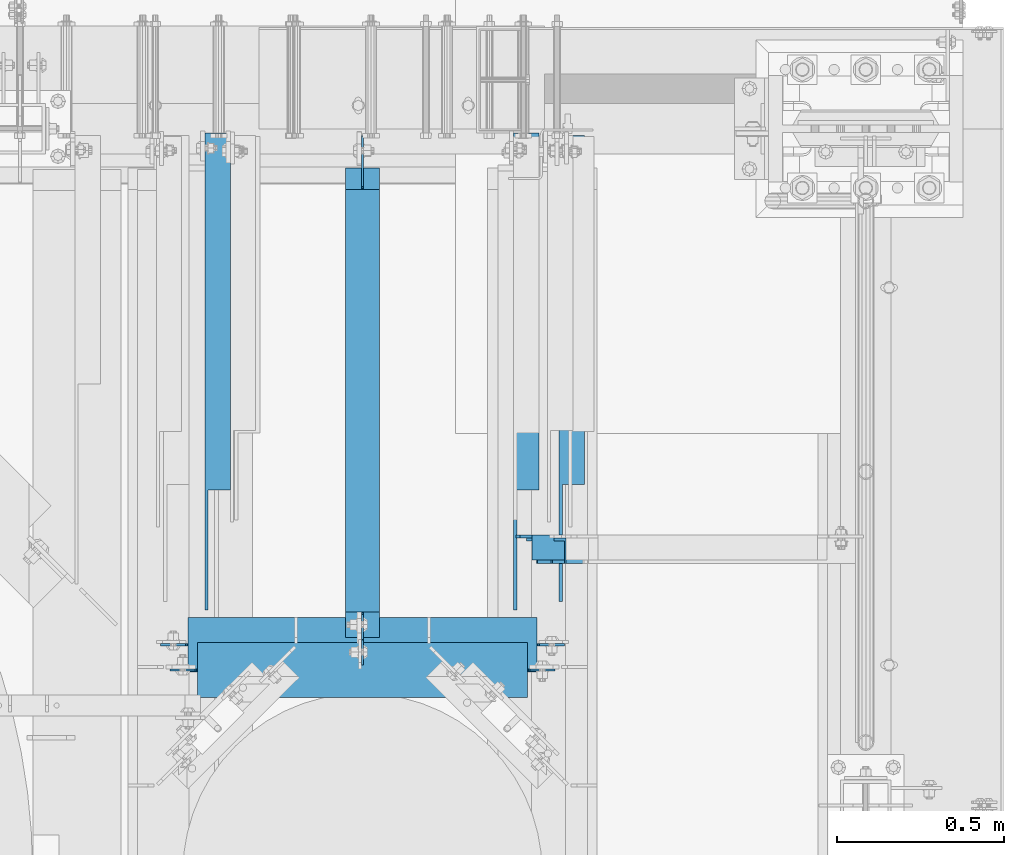
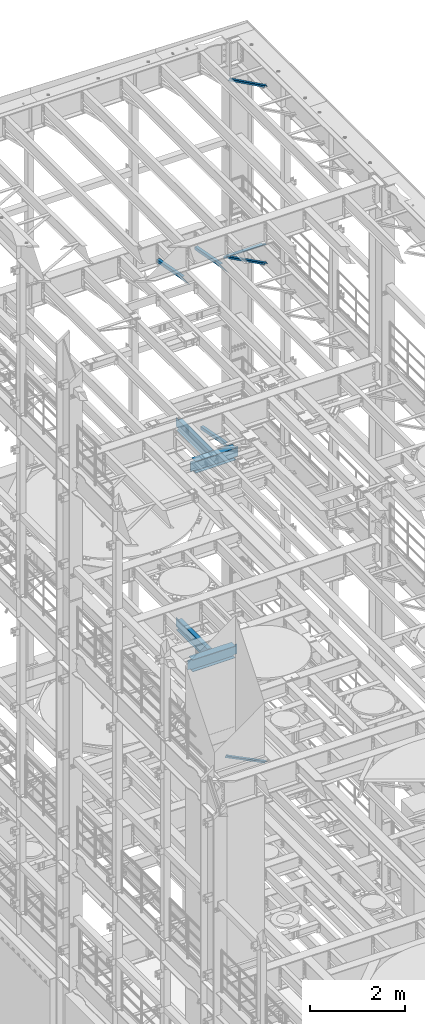
# One storey, part 1069 of 1876: 8 beams, 3 members, 11 elements without a shape of their own.
"""IFC2X3 building model written with IfcOpenShell, lengths in millimetres."""

import ifcopenshell
import ifcopenshell.guid

model = None  # the IFC model being written
_history = None  # IfcOwnerHistory: only IFC2X3 demands one
_inside = {}  # id of a spatial element -> (the spatial element, [elements in it])
_under = {}  # id of a project, library or spatial element -> (it, [spatial elements below it])
_declared = {}  # id of a project -> (the project, [libraries it declares])
_typed = {}  # id of a type object -> (the type object, [elements of that type])
_made_of = {}  # id of a material, layer set ... -> (it, [elements and type objects made of it])


def new_model(schema):
    """Start an empty IFC model of exactly this schema.

    Asked for "IFC4X3", IfcOpenShell would pick the latest addendum, in which some entities
    have other attributes; the version numbers below select the first issue.
    IFC2X3 requires an IfcOwnerHistory on every rooted entity: one is made here for all.
    """
    global model, _history
    if schema == "IFC4X3":
        model = ifcopenshell.file(schema_version=(4, 3, 0, 0))
    else:
        model = ifcopenshell.file(schema=schema)
    _inside.clear()
    _under.clear()
    _declared.clear()
    _typed.clear()
    _made_of.clear()
    _history = None
    if model.schema == "IFC2X3":
        org = make("IfcOrganization", Name="unknown")
        user = make(
            "IfcPersonAndOrganization",
            ThePerson=make("IfcPerson", FamilyName="unknown"),
            TheOrganization=org,
        )
        app = make(
            "IfcApplication",
            ApplicationDeveloper=org,
            Version="unknown",
            ApplicationFullName="unknown",
            ApplicationIdentifier="unknown",
        )
        _history = make(
            "IfcOwnerHistory",
            OwningUser=user,
            OwningApplication=app,
            ChangeAction="ADDED",
            CreationDate=0,
        )
    return model


def make(cls, **values):
    """One entity of the class cls with the attributes given. An attribute that is None is left unset."""
    return model.create_entity(
        cls, **{name: value for name, value in values.items() if value is not None}
    )


def rooted(cls, **values):
    """An entity with a GlobalId (a new one), such as an element, a storey or a relation."""
    return make(cls, GlobalId=ifcopenshell.guid.new(), OwnerHistory=_history, **values)


def si_unit(unit_type, name, prefix=None):
    """IfcSIUnit, for example si_unit("LENGTHUNIT", "METRE", prefix="MILLI")."""
    return make("IfcSIUnit", UnitType=unit_type, Prefix=prefix, Name=name)


def assignment(units):
    """IfcUnitAssignment: the units of a project."""
    return None if units is None else make("IfcUnitAssignment", Units=units)


def point(xyz):
    """IfcCartesianPoint."""
    return None if xyz is None else make("IfcCartesianPoint", Coordinates=xyz)


def direction(xyz):
    """IfcDirection."""
    return None if xyz is None else make("IfcDirection", DirectionRatios=xyz)


def frame(location, z_axis=None, x_axis=None):
    """IfcAxis2Placement3D, a coordinate frame: its origin and axes. An axis left out is left unset."""
    return make(
        "IfcAxis2Placement3D",
        Location=point(location),
        Axis=direction(z_axis),
        RefDirection=direction(x_axis),
    )


def origin_with_axes():
    """The frame at (0, 0, 0) with the z axis (0, 0, 1) and the x axis (1, 0, 0) written out."""
    return frame((0.0, 0.0, 0.0), z_axis=(0.0, 0.0, 1.0), x_axis=(1.0, 0.0, 0.0))


def place(relative_to, where):
    """IfcLocalPlacement: puts the frame where relative to a parent placement (None: the world)."""
    return make(
        "IfcLocalPlacement", PlacementRelTo=relative_to, RelativePlacement=where
    )


def context(
    kind, dimensions, precision=None, world=None, true_north=None, identifier=None
):
    """IfcGeometricRepresentationContext, for example the 3D "Model" context."""
    return make(
        "IfcGeometricRepresentationContext",
        ContextIdentifier=identifier,
        ContextType=kind,
        CoordinateSpaceDimension=dimensions,
        Precision=precision,
        WorldCoordinateSystem=world,
        TrueNorth=true_north,
    )


def subcontext(parent, identifier, kind, view, scale=None):
    """IfcGeometricRepresentationSubContext, for example "Body" below "Model"."""
    return make(
        "IfcGeometricRepresentationSubContext",
        ContextIdentifier=identifier,
        ContextType=kind,
        ParentContext=parent,
        TargetScale=scale,
        TargetView=view,
    )


def project(units=None, contexts=None):
    """IfcProject with its units and contexts."""
    return rooted(
        "IfcProject",
        Name="project",
        RepresentationContexts=contexts,
        UnitsInContext=assignment(units),
    )


def spatial(cls, under=None, at=None, **own):
    """A site, building, storey or space (cls), placed at a placement, below another one or the project."""
    s = rooted(cls, ObjectPlacement=at, **own)
    if under is not None:
        _under.setdefault(under.id(), (under, []))[1].append(s)
    return s


def faces_of(points, faces, orient=None, outer=None):
    """IfcFace entities. A face is a list of loops; a loop is a list of indices into points, from 0.

    orient and outer hold one flag for each loop. By default every Orientation is true, the
    first loop of a face is its IfcFaceOuterBound and the others are IfcFaceBound.
    """
    made = []
    for i, loops in enumerate(faces):
        bounds = []
        for j, loop in enumerate(loops):
            is_outer = j == 0 if outer is None else outer[i][j]
            bounds.append(
                make(
                    "IfcFaceOuterBound" if is_outer else "IfcFaceBound",
                    Bound=make("IfcPolyLoop", Polygon=[points[k] for k in loop]),
                    Orientation=True if orient is None else orient[i][j],
                )
            )
        made.append(make("IfcFace", Bounds=bounds))
    return made


def faceted_brep(points, faces, orient=None, outer=None, voids=None):
    """IfcFacetedBrep: a solid bounded by flat faces; with voids (closed shells), ...WithVoids."""
    shared = [point(p) for p in points]
    hull = make("IfcClosedShell", CfsFaces=faces_of(shared, faces, orient, outer))
    if voids is None:
        return make("IfcFacetedBrep", Outer=hull)
    return make(
        "IfcFacetedBrepWithVoids",
        Outer=hull,
        Voids=[
            make(cls, CfsFaces=faces_of(shared, fs, o, b)) for cls, fs, o, b in voids
        ],
    )


def shape(context_of_items, identifier, shape_type, items):
    """IfcShapeRepresentation: the items that make up one representation, for example the "Body"."""
    return make(
        "IfcShapeRepresentation",
        ContextOfItems=context_of_items,
        RepresentationIdentifier=identifier,
        RepresentationType=shape_type,
        Items=items,
    )


def material(Name=None, Category=None):
    """IfcMaterial."""
    return make("IfcMaterial", Name=Name, Category=Category)


def made_of(thing, what):
    """Note that an element or type object is made of a material, layer set ...; save() writes the relation."""
    if what is not None:
        _made_of.setdefault(what.id(), (what, []))[1].append(thing)
    return thing


def type_object(cls, material=None, **own):
    """A type object (cls), such as IfcWallType, which elements share."""
    return made_of(rooted(cls, **own), material)


def element(
    cls,
    number,
    at=None,
    inside=None,
    cuts=None,
    type_object=None,
    material=None,
    context=None,
    identifier="Body",
    shape_type=None,
    held_by="IfcProductDefinitionShape",
    body=None,
    shapes=None,
    **own,
):
    """One element of the class cls, such as IfcWall. Its Tag is "e" and its number.

    at: its placement. inside: the storey or other place that contains it. cuts: it is an
    opening in that element (IfcRelVoidsElement). A single representation is given by context,
    identifier, shape_type and body (its items); several are given by shapes. held_by: the class
    of the entity that holds the representations. save() writes the other relations.
    """
    e = rooted(cls, Tag="e%d" % number, ObjectPlacement=at, **own)
    if body is not None:
        shapes = [shape(context, identifier, shape_type, body)]
    if shapes is not None:
        e.Representation = make(held_by, Representations=shapes)
    if inside is not None:
        _inside.setdefault(inside.id(), (inside, []))[1].append(e)
    if cuts is not None:
        rooted(
            "IfcRelVoidsElement", RelatingBuildingElement=cuts, RelatedOpeningElement=e
        )
    if type_object is not None:
        _typed.setdefault(type_object.id(), (type_object, []))[1].append(e)
    return made_of(e, material)


def aggregate(whole, parts):
    """IfcRelAggregates: a whole, such as a stair, and the parts it consists of."""
    return rooted("IfcRelAggregates", RelatingObject=whole, RelatedObjects=parts)


def save(model, path):
    """Write the relations noted so far, then the file.

    IfcRelAggregates (storeys below a building ...), IfcRelContainedInSpatialStructure (elements
    in a storey), IfcRelDefinesByType, IfcRelAssociatesMaterial and IfcRelDeclares: one each for
    every whole, place, type object, material and project.
    """
    for whole, parts in _under.values():
        aggregate(whole, parts)
    for where, things in _inside.values():
        rooted(
            "IfcRelContainedInSpatialStructure",
            RelatedElements=things,
            RelatingStructure=where,
        )
    for kind, things in _typed.values():
        rooted("IfcRelDefinesByType", RelatedObjects=things, RelatingType=kind)
    for what, things in _made_of.values():
        rooted("IfcRelAssociatesMaterial", RelatedObjects=things, RelatingMaterial=what)
    for by, libraries in _declared.values():
        rooted("IfcRelDeclares", RelatingContext=by, RelatedDefinitions=libraries)
    model.write(path)


model = new_model("IFC2X3")

# Units and contexts
model_context = context("Model", 3, precision=1e-05, world=origin_with_axes())
body_context = subcontext(model_context, "Body", "Model", "MODEL_VIEW")
ifc_project = project(units=[si_unit("LENGTHUNIT", "METRE", prefix="MILLI"), si_unit("AREAUNIT", "SQUARE_METRE"), si_unit("VOLUMEUNIT", "CUBIC_METRE"), si_unit("MASSUNIT", "GRAM", prefix="KILO"), si_unit("TIMEUNIT", "SECOND"), si_unit("PLANEANGLEUNIT", "RADIAN"), si_unit("SOLIDANGLEUNIT", "STERADIAN"), si_unit("THERMODYNAMICTEMPERATUREUNIT", "DEGREE_CELSIUS"), si_unit("LUMINOUSINTENSITYUNIT", "LUMEN")], contexts=[model_context])

# Site, building, storey
site_placement = place(None, origin_with_axes())
site = spatial("IfcSite", under=ifc_project, at=site_placement, CompositionType="ELEMENT")
building_placement = place(site_placement, origin_with_axes())
building = spatial("IfcBuilding", under=site, at=building_placement, Name="Undefined", CompositionType="ELEMENT")
storey_placement = place(building_placement, origin_with_axes())
storey = spatial("IfcBuildingStorey", under=building, at=storey_placement, Name="Undefined", CompositionType="ELEMENT", Elevation=0.0)

# Assembly, member
assembly_1_placement = place(storey_placement, origin_with_axes())
assembly_1 = element("IfcElementAssembly", 1, at=assembly_1_placement, inside=storey, AssemblyPlace="NOTDEFINED", PredefinedType="RIGID_FRAME")
ifc_material_1 = material(Name="STEEL/A36")
member_type = type_object("IfcMemberType", Name="L3X3X3/8", PredefinedType="NOTDEFINED")
member_1_placement = place(assembly_1_placement, frame((6546.00359127146, 12449.175, 5110.24886127725), z_axis=(0.0, -1.0, 0.0), x_axis=(0.894904191539842, 0.0, -0.446258319770535)))
member_1 = element("IfcMember", 2, at=member_1_placement, type_object=member_type, material=ifc_material_1, ObjectType="L3X3X3/8", context=body_context, shape_type="Brep", body=[
    faceted_brep([(80.1547206858395, 38.100000000054, -38.1000000000004), (80.1547206858395, 38.100000000054, 38.1000000000004), (1158.95112186373, 38.1000000006807, 38.1000000000004), (1158.95112186373, 38.1000000006807, -38.1000000000004), (80.1547206858399, 28.5750000000526, 38.1000000000004), (1158.95112186373, 28.5750000006792, 38.1000000000004), (80.1547206858399, 28.5750000000526, -28.5750000000007), (1158.95112186373, 28.5750000006792, -28.5750000000007), (80.154720685839, -38.0999999999594, -28.5750000000007), (1158.95112186373, -38.0999999993337, -28.5750000000007), (80.154720685839, -38.0999999999594, -38.1000000000004), (1158.95112186373, -38.0999999993337, -38.1000000000004)], [[[0, 1, 2, 3]], [[1, 4, 5, 2]], [[4, 6, 7, 5]], [[6, 8, 9, 7]], [[8, 10, 11, 9]], [[10, 0, 3, 11]], [[5, 7, 9, 11, 3, 2]], [[10, 8, 6, 4, 1, 0]]]),
])
aggregate(assembly_1, [member_1])

assembly_2_placement = place(storey_placement, origin_with_axes())
assembly_2 = element("IfcElementAssembly", 3, at=assembly_2_placement, inside=storey, AssemblyPlace="NOTDEFINED", PredefinedType="RIGID_FRAME")
member_2_placement = place(assembly_2_placement, frame((6649.22451200342, 12449.175, 22521.7692276093), z_axis=(0.0, -1.0, 0.0), x_axis=(0.877448093107094, 0.0, -0.479671600058544)))
member_2 = element("IfcMember", 4, at=member_2_placement, type_object=member_type, material=ifc_material_1, ObjectType="L3X3X3/8", context=body_context, shape_type="Brep", body=[
    faceted_brep([(59.7482362440578, 38.0999999998749, -38.0999999999999), (59.7482362440578, 38.0999999998749, 38.0999999999999), (1062.91900040893, 38.0999999984488, 38.0999999999999), (1062.91900040893, 38.0999999984488, -38.0999999999999), (59.7482362440696, 28.5749999998843, 38.0999999999999), (1062.91900040895, 28.5749999984582, 38.0999999999999), (59.7482362440696, 28.5749999998843, -28.5749999999998), (1062.91900040895, 28.5749999984582, -28.5749999999998), (59.7482362441442, -38.1000000000495, -28.5749999999998), (1062.91900040902, -38.1000000014719, -28.5749999999998), (59.7482362441442, -38.1000000000495, -38.0999999999999), (1062.91900040902, -38.1000000014719, -38.0999999999999)], [[[0, 1, 2, 3]], [[1, 4, 5, 2]], [[4, 6, 7, 5]], [[6, 8, 9, 7]], [[8, 10, 11, 9]], [[10, 0, 3, 11]], [[5, 7, 9, 11, 3, 2]], [[10, 8, 6, 4, 1, 0]]]),
])
aggregate(assembly_2, [member_2])

assembly_3_placement = place(storey_placement, origin_with_axes())
assembly_3 = element("IfcElementAssembly", 5, at=assembly_3_placement, inside=storey, AssemblyPlace="NOTDEFINED", PredefinedType="RIGID_FRAME")
member_3_placement = place(assembly_3_placement, frame((6548.05484608427, 12449.175, 17987.6375508032), z_axis=(0.0, -1.0, 0.0), x_axis=(0.883528850284789, 0.0, -0.46837674015096)))
member_3 = element("IfcMember", 6, at=member_3_placement, type_object=member_type, material=ifc_material_1, ObjectType="L3X3X3/8", context=body_context, shape_type="Brep", body=[
    faceted_brep([(128.795891913077, 38.1000000000095, -38.0999999999999), (128.795891913077, 38.1000000000095, 38.0999999999999), (1170.59703232476, 38.0999999999913, 38.0999999999999), (1170.59703232476, 38.0999999999913, -38.0999999999999), (128.795891913076, 28.575000000008, 38.0999999999999), (1170.59703232476, 28.5749999999898, 38.0999999999999), (128.795891913076, 28.575000000008, -28.5749999999998), (1170.59703232476, 28.5749999999898, -28.5749999999998), (128.79589191308, -38.1000000000167, -28.5749999999998), (1170.59703232476, -38.1000000000313, -28.5749999999998), (128.79589191308, -38.1000000000167, -38.0999999999999), (1170.59703232476, -38.1000000000313, -38.0999999999999)], [[[0, 1, 2, 3]], [[1, 4, 5, 2]], [[4, 6, 7, 5]], [[6, 8, 9, 7]], [[8, 10, 11, 9]], [[10, 0, 3, 11]], [[5, 7, 9, 11, 3, 2]], [[10, 8, 6, 4, 1, 0]]]),
])
aggregate(assembly_3, [member_3])

# Assembly, beam
assembly_4_placement = place(storey_placement, origin_with_axes())
assembly_4 = element("IfcElementAssembly", 7, at=assembly_4_placement, inside=storey, Name="BEAM", AssemblyPlace="NOTDEFINED", PredefinedType="RIGID_FRAME")
ifc_material_2 = material(Name="STEEL/A992")
beam_type_1 = type_object("IfcBeamType", Name="W12X26", PredefinedType="NOTDEFINED")
beam_1_placement = place(assembly_4_placement, frame((5524.5, 12090.4528934785, 13154.025), z_axis=(0.0, 0.0, 1.0), x_axis=(1.0, 0.0, 0.0)))
beam_1 = element("IfcBeam", 8, at=beam_1_placement, type_object=beam_type_1, material=ifc_material_2, Name="BEAM", ObjectType="W12X26", context=body_context, shape_type="Brep", body=[
    faceted_brep([(1073.15, -3.17499999999927, -146.049999999999), (1073.15, -82.5499999999993, -146.049999999999), (1073.15, -82.5499999999993, -155.575000000001), (1073.15, 82.5499999999993, -155.575000000001), (1073.15, 82.5499999999993, -146.049999999999), (1073.15, 3.17499999999927, -146.049999999999), (1073.15, 3.17499999999927, -142.874999809266), (1073.15, -3.17499999999927, -142.874999809266), (1074.11672992259, 3.17499999999927, -138.01492029122), (1074.11672992259, -3.17499999999927, -138.01492029122), (1076.86974382307, 3.17499999999927, -133.894743823066), (1076.86974382307, -3.17499999999927, -133.894743823066), (1080.98992029122, 3.17499999999927, -131.141729922589), (1080.98992029122, -3.17499999999927, -131.141729922589), (1085.84999980927, 3.17499999999927, -130.175000000001), (1085.84999980927, -3.17499999999927, -130.175000000001), (1162.05, -3.17499999999927, -130.175000000001), (1162.05, 3.17499999999927, -130.175000000001), (1079.5, 82.5499999999993, 146.049999999999), (1079.5, 3.17499999999927, 146.049999999999), (88.8999999999996, 3.17499999999927, 146.049999999999), (88.8999999999996, 82.5499999999993, 146.049999999999), (95.2499999999991, -3.17499999999927, -142.874999809266), (95.2499999999991, 3.17499999999927, -142.874999809266), (95.2499999999991, 3.17499999999927, -146.049999999999), (95.2499999999991, 82.5499999999993, -146.049999999999), (95.2499999999991, 82.5499999999993, -155.575000000001), (95.2499999999991, -82.5499999999993, -155.575000000001), (95.2499999999991, -82.5499999999993, -146.049999999999), (95.2499999999991, -3.17499999999927, -146.049999999999), (94.2832700774115, -3.17499999999927, -138.01492029122), (94.2832700774115, 3.17499999999927, -138.01492029122), (91.5302561769331, -3.17499999999927, -133.894743823066), (91.5302561769331, 3.17499999999927, -133.894743823066), (87.4100797087794, -3.17499999999927, -131.141729922589), (87.4100797087794, 3.17499999999927, -131.141729922589), (82.550000190734, -3.17499999999927, -130.175000000001), (82.550000190734, 3.17499999999927, -130.175000000001), (6.34999999999945, -3.17499999999927, -130.175000000001), (6.34999999999945, 3.17499999999927, -130.175000000001), (6.34999999999945, -3.17499999999927, 130.175000000001), (6.34999999999945, 3.17499999999927, 130.175000000001), (76.2000001907345, -3.17499999999927, 130.175000000001), (76.2000001907345, 3.17499999999927, 130.175000000001), (81.06007970878, -3.17499999999927, 131.141729922589), (81.06007970878, 3.17499999999927, 131.141729922589), (85.1802561769337, -3.17499999999927, 133.894743823066), (85.1802561769337, 3.17499999999927, 133.894743823066), (87.9332700774121, -3.17499999999927, 138.01492029122), (87.9332700774121, 3.17499999999927, 138.01492029122), (88.8999999999996, -3.17499999999927, 142.874999809266), (88.8999999999996, 3.17499999999927, 142.874999809266), (88.8999999999996, -82.5499999999993, 155.575000000001), (88.8999999999996, 82.5499999999993, 155.575000000001), (88.8999999999996, -3.17499999999927, 146.049999999999), (88.8999999999996, -82.5499999999993, 146.049999999999), (1079.5, -3.17499999999927, 146.049999999999), (1079.5, -82.5499999999993, 146.049999999999), (1079.5, -82.5499999999993, 155.575000000001), (1079.5, 82.5499999999993, 155.575000000001), (1079.5, -3.17499999999927, 142.874999809266), (1079.5, 3.17499999999927, 142.874999809266), (1080.46672992259, -3.17499999999927, 138.01492029122), (1080.46672992259, 3.17499999999927, 138.01492029122), (1083.21974382307, -3.17499999999927, 133.894743823066), (1083.21974382307, 3.17499999999927, 133.894743823066), (1087.33992029122, -3.17499999999927, 131.141729922589), (1087.33992029122, 3.17499999999927, 131.141729922589), (1092.19999980927, -3.17499999999927, 130.175000000001), (1092.19999980927, 3.17499999999927, 130.175000000001), (1162.05, -3.17499999999927, 130.175000000001), (1162.05, 3.17499999999927, 130.175000000001)], [[[0, 1, 2, 3, 4, 5, 6, 7]], [[7, 6, 8, 9]], [[9, 8, 10, 11]], [[11, 10, 12, 13]], [[13, 12, 14, 15]], [[16, 15, 14, 17]], [[18, 19, 20, 21]], [[22, 23, 24, 25, 26, 27, 28, 29]], [[30, 31, 23, 22]], [[32, 33, 31, 30]], [[34, 35, 33, 32]], [[36, 37, 35, 34]], [[38, 39, 37, 36]], [[40, 41, 39, 38]], [[42, 43, 41, 40]], [[44, 45, 43, 42]], [[46, 47, 45, 44]], [[48, 49, 47, 46]], [[50, 51, 49, 48]], [[52, 53, 21, 20, 51, 50, 54, 55]], [[56, 57, 55, 54]], [[57, 58, 52, 55]], [[58, 59, 53, 52]], [[59, 18, 21, 53]], [[58, 57, 56, 60, 61, 19, 18, 59]], [[62, 63, 61, 60]], [[64, 65, 63, 62]], [[66, 67, 65, 64]], [[68, 69, 67, 66]], [[70, 71, 69, 68]], [[71, 70, 16, 17]], [[33, 35, 37, 39, 41, 43, 45, 47, 49, 51, 20, 19, 61, 63, 65, 67, 69, 71, 17, 14, 12, 10, 8, 6, 5, 24, 23, 31]], [[5, 4, 25, 24]], [[4, 3, 26, 25]], [[3, 2, 27, 26]], [[2, 1, 28, 27]], [[1, 0, 29, 28]], [[0, 7, 9, 11, 13, 15, 16, 70, 68, 66, 64, 62, 60, 56, 54, 50, 48, 46, 44, 42, 40, 38, 36, 34, 32, 30, 22, 29]]]),
])
aggregate(assembly_4, [beam_1])

assembly_5_placement = place(storey_placement, origin_with_axes())
assembly_5 = element("IfcElementAssembly", 9, at=assembly_5_placement, inside=storey, Name="BEAM", AssemblyPlace="NOTDEFINED", PredefinedType="RIGID_FRAME")
beam_2_placement = place(assembly_5_placement, frame((5486.4, 12166.6, 7997.825), z_axis=(0.0, 0.0, -1.0), x_axis=(1.0, 0.0, 0.0)))
beam_2 = element("IfcBeam", 10, at=beam_2_placement, type_object=beam_type_1, material=ifc_material_1, Name="BEAM", ObjectType="W12X26", context=body_context, shape_type="Brep", body=[
    faceted_brep([(1146.175, -3.17499999999927, -146.05), (1146.175, -82.5499999999993, -146.05), (1146.175, -82.5499999999993, -155.575), (1146.175, 82.5499999999993, -155.575), (1146.175, 82.5499999999993, -146.05), (1146.175, 3.17499999999927, -146.05), (1146.175, 3.17499999999927, -142.874999809266), (1146.175, -3.17499999999927, -142.874999809266), (1147.14172992259, 3.17499999999927, -138.014920291221), (1147.14172992259, -3.17499999999927, -138.014920291221), (1149.89474382307, 3.17499999999927, -133.894743823067), (1149.89474382307, -3.17499999999927, -133.894743823067), (1154.01492029122, 3.17499999999927, -131.141729922589), (1154.01492029122, -3.17499999999927, -131.141729922589), (1158.87499980927, 3.17499999999927, -130.175000000001), (1158.87499980927, -3.17499999999927, -130.175000000001), (1228.725, -3.17499999999927, -130.175000000001), (1228.725, 3.17499999999927, -130.175000000001), (1139.825, 82.5499999999993, 146.05), (1139.825, 3.17499999999927, 146.05), (104.774999999999, 3.17499999999927, 146.05), (104.774999999999, 82.5499999999993, 146.05), (98.4250000000002, -3.17500000000018, -142.874999809268), (98.4250000000002, 3.17500000000018, -142.874999809268), (98.4250000000029, 3.17500000000018, -146.049999999999), (98.4250000000002, 82.5500000000002, -146.049999999999), (98.4250000000002, 82.5500000000002, -155.575000000001), (98.4250000000002, -82.5500000000002, -155.575000000001), (98.4250000000002, -82.5500000000002, -146.049999999999), (98.4250000000029, -3.17500000000018, -146.049999999999), (97.4582700774126, -3.17500000000018, -138.014920291222), (97.4582700774126, 3.17500000000018, -138.014920291222), (94.7052561769342, -3.17500000000018, -133.894743823068), (94.7052561769342, 3.17500000000018, -133.894743823068), (90.5850797087805, -3.17500000000018, -131.14172992259), (90.5850797087805, 3.17500000000018, -131.14172992259), (85.725000190735, -3.17500000000018, -130.175000000003), (85.725000190735, 3.17500000000018, -130.175000000003), (15.875, -3.17500000000018, -130.175000000003), (15.875, 3.17500000000018, -130.175000000003), (15.8749999999991, -3.17499999999927, 123.824999999999), (15.8749999999991, 3.17499999999927, 123.824999999999), (92.0750001907336, -3.17499999999927, 123.824999999999), (92.0750001907336, 3.17499999999927, 123.824999999999), (96.9350797087791, -3.17499999999927, 124.791729922586), (96.9350797087791, 3.17499999999927, 124.791729922586), (101.055256176933, -3.17499999999927, 127.544743823065), (101.055256176933, 3.17499999999927, 127.544743823065), (103.808270077411, -3.17499999999927, 131.664920291219), (103.808270077411, 3.17499999999927, 131.664920291219), (104.774999999999, -3.17499999999927, 136.524999809264), (104.774999999999, 3.17499999999927, 136.524999809264), (1139.825, -82.5499999999993, 155.575), (1139.825, 82.5499999999993, 155.575), (104.774999999999, 82.5499999999993, 155.575), (104.774999999999, -82.5499999999993, 155.575), (1139.825, -82.5499999999993, 146.05), (104.774999999999, -82.5499999999993, 146.05), (1139.825, -3.17499999999927, 146.05), (104.774999999999, -3.17499999999927, 146.05), (1139.825, -3.17499999999927, 136.524999809264), (1139.825, 3.17499999999927, 136.524999809264), (1140.79172992259, -3.17499999999927, 131.664920291219), (1140.79172992259, 3.17499999999927, 131.664920291219), (1143.54474382307, -3.17499999999927, 127.544743823065), (1143.54474382307, 3.17499999999927, 127.544743823065), (1147.66492029122, -3.17499999999927, 124.791729922586), (1147.66492029122, 3.17499999999927, 124.791729922586), (1152.52499980927, -3.17499999999927, 123.824999999999), (1152.52499980927, 3.17499999999927, 123.824999999999), (1228.725, -3.17499999999927, 123.824999999999), (1228.725, 3.17499999999927, 123.824999999999)], [[[0, 1, 2, 3, 4, 5, 6, 7]], [[7, 6, 8, 9]], [[9, 8, 10, 11]], [[11, 10, 12, 13]], [[13, 12, 14, 15]], [[16, 15, 14, 17]], [[18, 19, 20, 21]], [[22, 23, 24, 25, 26, 27, 28, 29]], [[30, 31, 23, 22]], [[32, 33, 31, 30]], [[34, 35, 33, 32]], [[36, 37, 35, 34]], [[38, 39, 37, 36]], [[40, 41, 39, 38]], [[42, 43, 41, 40]], [[44, 45, 43, 42]], [[46, 47, 45, 44]], [[48, 49, 47, 46]], [[50, 51, 49, 48]], [[52, 53, 54, 55]], [[56, 52, 55, 57]], [[58, 56, 57, 59]], [[55, 54, 21, 20, 51, 50, 59, 57]], [[53, 18, 21, 54]], [[52, 56, 58, 60, 61, 19, 18, 53]], [[62, 63, 61, 60]], [[64, 65, 63, 62]], [[66, 67, 65, 64]], [[68, 69, 67, 66]], [[70, 71, 69, 68]], [[71, 70, 16, 17]], [[12, 10, 8, 6, 5, 24, 23, 31, 33, 35, 37, 39, 41, 43, 45, 47, 49, 51, 20, 19, 61, 63, 65, 67, 69, 71, 17, 14]], [[25, 24, 5, 4]], [[26, 25, 4, 3]], [[27, 26, 3, 2]], [[28, 27, 2, 1]], [[29, 28, 1, 0]], [[70, 68, 66, 64, 62, 60, 58, 59, 50, 48, 46, 44, 42, 40, 38, 36, 34, 32, 30, 22, 29, 0, 7, 9, 11, 13, 15, 16]]]),
])
aggregate(assembly_5, [beam_2])

assembly_6_placement = place(storey_placement, origin_with_axes())
assembly_6 = element("IfcElementAssembly", 11, at=assembly_6_placement, inside=storey, AssemblyPlace="NOTDEFINED", PredefinedType="RIGID_FRAME")
beam_type_2 = type_object("IfcBeamType", Name="L3X3X3/8", PredefinedType="NOTDEFINED")
beam_3_placement = place(assembly_6_placement, frame((6737.35, 12498.433225377, 13004.4929171211), z_axis=(1.0, 0.0, 0.0), x_axis=(0.0, 0.981826447972761, -0.189780994994735)))
beam_3 = element("IfcBeam", 12, at=beam_3_placement, type_object=beam_type_2, material=ifc_material_1, ObjectType="L3X3X3/8", context=body_context, shape_type="Brep", body=[
    faceted_brep([(-198.727330666601, -38.0999999999294, -38.1000000000004), (-198.727330666601, -38.0999999999294, -28.5749999999998), (146.213839129041, 28.574999999948, -28.5749999999998), (146.213839129041, 28.574999999948, 38.1000000000004), (195.491149099846, 38.0999999999294, 38.1000000000004), (195.491149099846, 38.0999999999294, -38.1000000000004), (1211.7198728657, 28.5749999995678, 38.1000000000004), (1211.7198728657, 38.0999999995674, 38.1000000000004), (1211.7198728657, 38.0999999995674, -38.1000000000004), (1211.7198728657, -38.1000000004333, -38.1000000000004), (1211.7198728657, -38.1000000004333, -28.5749999999998), (1211.7198728657, 28.5749999995678, -28.5749999999998)], [[[0, 1, 2, 3, 4, 5]], [[4, 3, 6, 7]], [[5, 4, 7, 8]], [[0, 5, 8, 9]], [[1, 0, 9, 10]], [[2, 1, 10, 11]], [[3, 2, 11, 6]], [[10, 9, 8, 7, 6, 11]]]),
])
aggregate(assembly_6, [beam_3])

assembly_7_placement = place(storey_placement, origin_with_axes())
assembly_7 = element("IfcElementAssembly", 13, at=assembly_7_placement, inside=storey, AssemblyPlace="NOTDEFINED", PredefinedType="RIGID_FRAME")
beam_4_placement = place(assembly_7_placement, frame((6600.825, 12478.7701585775, 17678.0584984364), z_axis=(1.0, 0.0, 0.0), x_axis=(0.0, 0.982729825630071, -0.185046182930343)))
beam_4 = element("IfcBeam", 14, at=beam_4_placement, type_object=beam_type_2, material=ifc_material_1, ObjectType="L3X3X3/8", context=body_context, shape_type="Brep", body=[
    faceted_brep([(200.493218531883, 38.099999999944, -38.1000000000004), (200.493218531883, 38.099999999944, 38.1000000000004), (1239.09835784596, 38.0999999993655, 38.1000000000004), (1239.09835784596, 38.0999999993655, -38.1000000000004), (149.908540475497, 28.5749999999571, 38.1000000000004), (1239.09863171315, 28.5749999993495, 38.1000000000004), (149.908540475497, 28.5749999999571, -28.5749999999998), (1239.09863171315, 28.5749999993495, -28.5749999999998), (-204.184205919202, -38.0999999999367, -28.5749999999998), (1239.10054878342, -38.1000000007407, -28.5749999999998), (-204.184205919202, -38.0999999999367, -38.1000000000004), (1239.10054878342, -38.1000000007407, -38.1000000000004)], [[[0, 1, 2, 3]], [[1, 4, 5, 2]], [[4, 6, 7, 5]], [[6, 8, 9, 7]], [[8, 10, 11, 9]], [[10, 0, 3, 11]], [[5, 7, 9, 11, 3, 2]], [[10, 8, 6, 4, 1, 0]]]),
])
aggregate(assembly_7, [beam_4])

assembly_8_placement = place(storey_placement, origin_with_axes())
assembly_8 = element("IfcElementAssembly", 15, at=assembly_8_placement, inside=storey, AssemblyPlace="NOTDEFINED", PredefinedType="RIGID_FRAME")
beam_5_placement = place(assembly_8_placement, frame((5673.725, 12478.7701585775, 17678.0584984364), z_axis=(1.0, 0.0, 0.0), x_axis=(0.0, 0.982729825630071, -0.185046182930343)))
beam_5 = element("IfcBeam", 16, at=beam_5_placement, type_object=beam_type_2, material=ifc_material_1, ObjectType="L3X3X3/8", context=body_context, shape_type="Brep", body=[
    faceted_brep([(200.493218531883, 38.099999999944, -38.1000000000004), (200.493218531883, 38.099999999944, 38.1000000000004), (1239.09835784596, 38.0999999993655, 38.1000000000004), (1239.09835784596, 38.0999999993655, -38.1000000000004), (149.908540475497, 28.5749999999571, 38.1000000000004), (1239.09863171315, 28.5749999993495, 38.1000000000004), (149.908540475497, 28.5749999999571, -28.5749999999998), (1239.09863171315, 28.5749999993495, -28.5749999999998), (-204.184205919202, -38.0999999999367, -28.5749999999998), (1239.10054878342, -38.1000000007407, -28.5749999999998), (-204.184205919202, -38.0999999999367, -38.1000000000004), (1239.10054878342, -38.1000000007407, -38.1000000000004)], [[[0, 1, 2, 3]], [[1, 4, 5, 2]], [[4, 6, 7, 5]], [[6, 8, 9, 7]], [[8, 10, 11, 9]], [[10, 0, 3, 11]], [[5, 7, 9, 11, 3, 2]], [[10, 8, 6, 4, 1, 0]]]),
])
aggregate(assembly_8, [beam_5])

assembly_9_placement = place(storey_placement, origin_with_axes())
assembly_9 = element("IfcElementAssembly", 17, at=assembly_9_placement, inside=storey, Name="ANGLE", AssemblyPlace="NOTDEFINED", PredefinedType="RIGID_FRAME")
beam_6_placement = place(assembly_9_placement, frame((6565.89999988253, 12458.7, 17945.1), z_axis=(0.0, -1.0, 0.0), x_axis=(1.0, 0.0, 0.0)))
beam_6 = element("IfcBeam", 18, at=beam_6_placement, type_object=beam_type_2, material=ifc_material_1, Name="ANGLE", ObjectType="L3X3X3/8", context=body_context, shape_type="Brep", body=[
    faceted_brep([(3.17499999075153, -38.0999999999985, -28.5749999999998), (3.17500032897624, 15.8750003814675, -28.5749999999998), (3.17500012894925, 15.8750003814675, -38.0999999999999), (3.17499999075153, -38.0999999999985, -38.0999999999999), (15.8749936676099, 28.5749999999989, -28.5750000000007), (15.8749999382144, 28.5750001907327, -38.0999999999999), (52.3875051486311, 28.5750000000007, -28.5750000000144), (52.3875058725339, 28.5750001907327, -38.1000000000149), (52.3875000813123, 28.5750001907327, 38.0999999999858), (52.3875000813496, 38.0999999999985, 38.0999999999858), (52.3875058725371, 38.0999999999985, -38.1000000000149), (1046.95625591089, -19.0500007629525, -38.0999999999999), (1046.95625603472, -19.0500007629525, -28.5749999999998), (1046.95625011747, -38.0999999999985, -28.5749999999998), (1046.95625011747, -38.0999999999985, -38.0999999999999), (1015.20625591089, 12.6999992370475, -38.0999999999999), (1015.20625603472, 12.6999992370475, -28.5749999999998), (938.213000295654, 12.6999992370475, -38.0999999999999), (938.213000419482, 12.6999992370475, -28.5749999999998), (938.213001286278, 28.5750000000007, 38.0999999999999), (938.213000419482, 28.5750000000007, -28.5749999999998), (938.213000295654, 38.0999999999985, -38.0999999999999), (938.213001286278, 38.0999999999985, 38.0999999999999)], [[[0, 1, 2, 3]], [[4, 5, 2, 1]], [[6, 7, 5, 4]], [[8, 9, 10, 7, 6]], [[11, 12, 13, 14]], [[15, 16, 12, 11]], [[16, 15, 17, 18]], [[19, 20, 18, 17, 21, 22]], [[8, 6, 20, 19]], [[16, 18, 20, 6, 4, 1, 0, 13, 12]], [[0, 3, 14, 13]], [[3, 2, 5, 7, 10, 21, 17, 15, 11, 14]], [[10, 9, 22, 21]], [[9, 8, 19, 22]]]),
])
aggregate(assembly_9, [beam_6])

assembly_10_placement = place(storey_placement, origin_with_axes())
assembly_10 = element("IfcElementAssembly", 19, at=assembly_10_placement, inside=storey, Name="BEAM", AssemblyPlace="NOTDEFINED", PredefinedType="RIGID_FRAME")
beam_type_3 = type_object("IfcBeamType", Name="W12X16", PredefinedType="NOTDEFINED")
beam_7_placement = place(assembly_10_placement, frame((6108.7, 12090.4528934785, 13157.2), z_axis=(0.0, 0.0, 1.0), x_axis=(0.0, 1.0, 0.0)))
beam_7 = element("IfcBeam", 20, at=beam_7_placement, type_object=beam_type_3, material=ifc_material_2, Name="BEAM", ObjectType="W12X16", context=body_context, shape_type="Brep", body=[
    faceted_brep([(15.875, -3.17500000000018, -120.649999999998), (15.875, 3.17500000000018, -120.649999999998), (85.7250001907378, 3.17500000000018, -120.649999999998), (85.7250001907378, -3.17500000000018, -120.649999999998), (90.5850797087842, 3.17500000000018, -121.616729922585), (90.5850797087842, -3.17500000000018, -121.616729922585), (94.7052561769378, 3.17500000000018, -124.369743823063), (94.7052561769378, -3.17500000000018, -124.369743823063), (97.4582700774154, 3.17500000000018, -128.489920291217), (97.4582700774154, -3.17500000000018, -128.489920291217), (98.4250000000029, -3.17500000000018, -133.349999809263), (98.4250000000029, 3.17500000000018, -133.349999809263), (98.4250000000029, 3.17500000000018, -146.049999999999), (98.4250000000029, 50.8000000000002, -146.049999999999), (98.4250000000029, 50.8000000000002, -152.4), (98.4250000000029, -50.8000000000002, -152.4), (98.4250000000029, -50.8000000000002, -146.049999999999), (98.4250000000029, -3.17500000000018, -146.049999999999), (1439.8096065215, 50.8000000000002, 146.049999999999), (1439.8096065215, 3.17500000000018, 146.049999999999), (98.4250000000029, 3.17500000000018, 146.049999999999), (98.4250000000029, 50.8000000000002, 146.049999999999), (85.7250001907378, -3.17500000000018, 120.650000000001), (85.7250001907378, 3.17500000000018, 120.650000000001), (15.875, 3.17500000000018, 120.650000000001), (15.875, -3.17500000000018, 120.650000000001), (90.5850797087842, -3.17500000000018, 121.616729922589), (90.5850797087842, 3.17500000000018, 121.616729922589), (94.7052561769378, -3.17500000000018, 124.369743823067), (94.7052561769378, 3.17500000000018, 124.369743823067), (97.4582700774154, -3.17500000000018, 128.48992029122), (97.4582700774154, 3.17500000000018, 128.48992029122), (98.4250000000029, -3.17500000000018, 133.349999809267), (98.4250000000029, 3.17500000000018, 133.349999809267), (1439.8096065215, -50.8000000000002, 152.4), (1439.8096065215, 50.8000000000002, 152.4), (98.4250000000029, 50.8000000000002, 152.4), (98.4250000000029, -50.8000000000002, 152.4), (1439.8096065215, -50.8000000000002, 146.049999999999), (98.4250000000029, -50.8000000000002, 146.049999999999), (1439.8096065215, -3.17500000000018, 146.049999999999), (98.4250000000029, -3.17500000000018, 146.049999999999), (1439.8096065215, -3.17500000000018, 120.649999809268), (1439.8096065215, 3.17500000000018, 120.649999809268), (1440.77633644409, -3.17500000000018, 115.789920291221), (1440.77633644409, 3.17500000000018, 115.789920291221), (1443.52935034457, -3.17500000000018, 111.669743823068), (1443.52935034457, 3.17500000000018, 111.669743823068), (1447.64952681272, -3.17500000000018, 108.91672992259), (1447.64952681272, 3.17500000000018, 108.91672992259), (1452.50960633077, -3.17500000000018, 107.950000000003), (1452.50960633077, 3.17500000000018, 107.950000000003), (1604.90960652151, -3.17500000000018, 107.950000000003), (1604.90960652151, 3.17500000000018, 107.950000000003), (1604.90960652151, -3.17500000000018, -126.999999999998), (1604.90960652151, 3.17500000000018, -126.999999999998), (1509.65960633077, -3.17500000000018, -126.999999999998), (1509.65960633077, 3.17500000000018, -126.999999999998), (1504.79952681272, -3.17500000000018, -127.966729922586), (1504.79952681272, 3.17500000000018, -127.966729922586), (1500.67935034457, -3.17500000000018, -130.719743823063), (1500.67935034457, 3.17500000000018, -130.719743823063), (1497.92633644409, -3.17500000000018, -134.839920291217), (1497.92633644409, 3.17500000000018, -134.839920291217), (1496.9596065215, -3.17500000000018, -139.699999809263), (1496.9596065215, 3.17500000000018, -139.699999809263), (1496.9596065215, -3.17500000000018, -146.049999999999), (1496.9596065215, -50.8000000000002, -146.049999999999), (1496.9596065215, -50.8000000000002, -152.4), (1496.9596065215, 50.8000000000002, -152.4), (1496.9596065215, 50.8000000000002, -146.049999999999), (1496.9596065215, 3.17500000000018, -146.049999999999)], [[[0, 1, 2, 3]], [[3, 2, 4, 5]], [[5, 4, 6, 7]], [[7, 6, 8, 9]], [[10, 11, 12, 13, 14, 15, 16, 17]], [[9, 8, 11, 10]], [[18, 19, 20, 21]], [[22, 23, 24, 25]], [[26, 27, 23, 22]], [[28, 29, 27, 26]], [[30, 31, 29, 28]], [[32, 33, 31, 30]], [[34, 35, 36, 37]], [[38, 34, 37, 39]], [[40, 38, 39, 41]], [[37, 36, 21, 20, 33, 32, 41, 39]], [[35, 18, 21, 36]], [[34, 38, 40, 42, 43, 19, 18, 35]], [[44, 45, 43, 42]], [[46, 47, 45, 44]], [[48, 49, 47, 46]], [[50, 51, 49, 48]], [[52, 53, 51, 50]], [[53, 52, 54, 55]], [[54, 56, 57, 55]], [[58, 59, 57, 56]], [[60, 61, 59, 58]], [[62, 63, 61, 60]], [[64, 65, 63, 62]], [[66, 67, 68, 69, 70, 71, 65, 64]], [[67, 66, 17, 16]], [[68, 67, 16, 15]], [[69, 68, 15, 14]], [[70, 69, 14, 13]], [[71, 70, 13, 12]], [[6, 4, 2, 1, 24, 23, 27, 29, 31, 33, 20, 19, 43, 45, 47, 49, 51, 53, 55, 57, 59, 61, 63, 65, 71, 12, 11, 8]], [[25, 24, 1, 0]], [[66, 64, 62, 60, 58, 56, 54, 52, 50, 48, 46, 44, 42, 40, 41, 32, 30, 28, 26, 22, 25, 0, 3, 5, 7, 9, 10, 17]]]),
])
aggregate(assembly_10, [beam_7])

assembly_11_placement = place(storey_placement, origin_with_axes())
assembly_11 = element("IfcElementAssembly", 21, at=assembly_11_placement, inside=storey, Name="BEAM", AssemblyPlace="NOTDEFINED", PredefinedType="RIGID_FRAME")
beam_8_placement = place(assembly_11_placement, frame((6108.7, 12166.6, 8001.0), z_axis=(0.0, 0.0, 1.0), x_axis=(0.0, 1.0, 0.0)))
beam_8 = element("IfcBeam", 22, at=beam_8_placement, type_object=beam_type_3, material=ifc_material_2, Name="BEAM", ObjectType="W12X16", context=body_context, shape_type="Brep", body=[
    faceted_brep([(15.875, -3.17500000000018, -120.649999999998), (15.875, 3.17500000000018, -120.649999999998), (85.7250001907378, 3.17500000000018, -120.649999999998), (85.7250001907378, -3.17500000000018, -120.649999999998), (90.5850797087842, 3.17500000000018, -121.616729922585), (90.5850797087842, -3.17500000000018, -121.616729922585), (94.7052561769378, 3.17500000000018, -124.369743823063), (94.7052561769378, -3.17500000000018, -124.369743823063), (97.4582700774154, 3.17500000000018, -128.489920291217), (97.4582700774154, -3.17500000000018, -128.489920291217), (98.4250000000029, -3.17500000000018, -133.349999809263), (98.4250000000029, 3.17500000000018, -133.349999809263), (98.4250000000029, 3.17500000000018, -146.049999999999), (98.4250000000029, 50.8000000000002, -146.049999999999), (98.4250000000029, 50.8000000000002, -152.4), (98.4250000000029, -50.8000000000002, -152.4), (98.4250000000029, -50.8000000000002, -146.049999999999), (98.4250000000029, -3.17500000000018, -146.049999999999), (1367.63125, 50.8000000000002, 146.05), (1367.63125, 3.17500000000018, 146.05), (98.4250000000029, 3.17500000000018, 146.049999999999), (98.4250000000029, 50.8000000000002, 146.049999999999), (85.7250001907378, -3.17500000000018, 120.650000000001), (85.7250001907378, 3.17500000000018, 120.650000000001), (15.875, 3.17500000000018, 120.650000000001), (15.875, -3.17500000000018, 120.650000000001), (90.5850797087842, -3.17500000000018, 121.616729922589), (90.5850797087842, 3.17500000000018, 121.616729922589), (94.7052561769378, -3.17500000000018, 124.369743823067), (94.7052561769378, 3.17500000000018, 124.369743823067), (97.4582700774154, -3.17500000000018, 128.48992029122), (97.4582700774154, 3.17500000000018, 128.48992029122), (98.4250000000029, -3.17500000000018, 133.349999809267), (98.4250000000029, 3.17500000000018, 133.349999809267), (1367.63125, -50.8000000000002, 152.4), (1367.63125, 50.8000000000002, 152.4), (98.4250000000029, 50.8000000000002, 152.4), (98.4250000000029, -50.8000000000002, 152.4), (1367.63125, -50.8000000000002, 146.05), (98.4250000000029, -50.8000000000002, 146.049999999999), (1367.63125, -3.17500000000018, 146.05), (98.4250000000029, -3.17500000000018, 146.049999999999), (1367.63125, -3.17500000000018, 114.299999809266), (1367.63125, 3.17500000000018, 114.299999809266), (1368.59797992259, -3.17500000000018, 109.43992029122), (1368.59797992259, 3.17500000000018, 109.43992029122), (1371.35099382307, -3.17500000000018, 105.319743823066), (1371.35099382307, 3.17500000000018, 105.319743823066), (1375.47117029122, -3.17500000000018, 102.566729922588), (1375.47117029122, 3.17500000000018, 102.566729922588), (1380.33124980927, -3.17500000000018, 101.6), (1380.33124980927, 3.17500000000018, 101.6), (1526.38125, -3.17500000000018, 101.6), (1526.38125, 3.17500000000018, 101.6), (1526.38125, -3.17500000000018, -127.0), (1526.38125, 3.17500000000018, -127.0), (1443.83124980927, -3.17500000000018, -127.0), (1443.83124980927, 3.17500000000018, -127.0), (1438.97117029122, -3.17500000000018, -127.966729922588), (1438.97117029122, 3.17500000000018, -127.966729922588), (1434.85099382307, -3.17500000000018, -130.719743823066), (1434.85099382307, 3.17500000000018, -130.719743823066), (1432.09797992259, -3.17500000000018, -134.83992029122), (1432.09797992259, 3.17500000000018, -134.83992029122), (1431.13125, -3.17500000000018, -139.699999809265), (1431.13125, 3.17500000000018, -139.699999809265), (1431.13125, -3.17500000000018, -146.05), (1431.13125, -50.8000000000002, -146.05), (1431.13125, -50.8000000000002, -152.4), (1431.13125, 50.8000000000002, -152.4), (1431.13125, 50.8000000000002, -146.05), (1431.13125, 3.17500000000018, -146.05)], [[[0, 1, 2, 3]], [[3, 2, 4, 5]], [[5, 4, 6, 7]], [[7, 6, 8, 9]], [[10, 11, 12, 13, 14, 15, 16, 17]], [[9, 8, 11, 10]], [[18, 19, 20, 21]], [[22, 23, 24, 25]], [[26, 27, 23, 22]], [[28, 29, 27, 26]], [[30, 31, 29, 28]], [[32, 33, 31, 30]], [[34, 35, 36, 37]], [[38, 34, 37, 39]], [[40, 38, 39, 41]], [[37, 36, 21, 20, 33, 32, 41, 39]], [[35, 18, 21, 36]], [[34, 38, 40, 42, 43, 19, 18, 35]], [[44, 45, 43, 42]], [[46, 47, 45, 44]], [[48, 49, 47, 46]], [[50, 51, 49, 48]], [[52, 53, 51, 50]], [[53, 52, 54, 55]], [[54, 56, 57, 55]], [[58, 59, 57, 56]], [[60, 61, 59, 58]], [[62, 63, 61, 60]], [[64, 65, 63, 62]], [[66, 67, 68, 69, 70, 71, 65, 64]], [[67, 66, 17, 16]], [[68, 67, 16, 15]], [[69, 68, 15, 14]], [[70, 69, 14, 13]], [[71, 70, 13, 12]], [[6, 4, 2, 1, 24, 23, 27, 29, 31, 33, 20, 19, 43, 45, 47, 49, 51, 53, 55, 57, 59, 61, 63, 65, 71, 12, 11, 8]], [[25, 24, 1, 0]], [[66, 64, 62, 60, 58, 56, 54, 52, 50, 48, 46, 44, 42, 40, 41, 32, 30, 28, 26, 22, 25, 0, 3, 5, 7, 9, 10, 17]]]),
])
aggregate(assembly_11, [beam_8])

save(model, "model.ifc")
